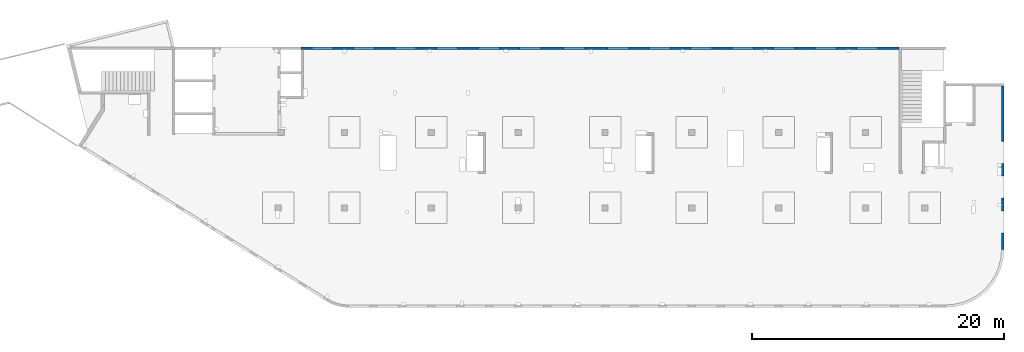
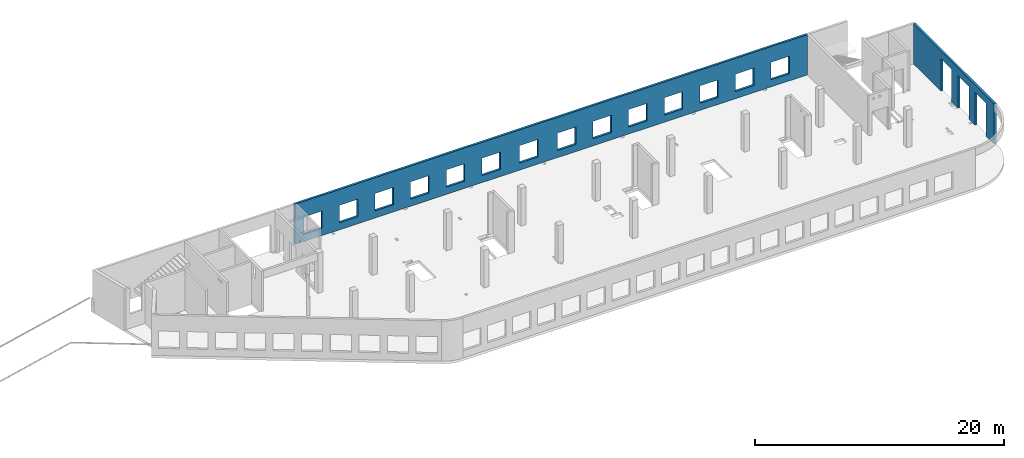
# One storey, part 7 of 7: 2 walls, 17 openings.
"""IFC4 building model written with IfcOpenShell, lengths in millimetres."""

from ifc_helpers import new_model, entity, si_unit, converted_unit, derived_unit, direction, frame, origin, place, context, subcontext, project, spatial, indexed_curve, outline, extrude, polygons, material, type_object, element, save


model = new_model("IFC4")

# Units and contexts
model_context = context("Model", 3, precision=0.01, world=origin(), true_north=direction((6.12303176911189e-17, 1.0)))
plan_context = context("Plan", 3, precision=0.01, world=origin(), true_north=direction((6.12303176911189e-17, 1.0)))
body_context = subcontext(model_context, "Body", "Model", "MODEL_VIEW")
ifc_project = project(units=[si_unit("LENGTHUNIT", "METRE", prefix="MILLI"), si_unit("AREAUNIT", "SQUARE_METRE"), si_unit("VOLUMEUNIT", "CUBIC_METRE"), converted_unit("PLANEANGLEUNIT", "DEGREE", entity("IfcRatioMeasure", 0.0174532925199433), si_unit("PLANEANGLEUNIT", "RADIAN"), dimensions=[0, 0, 0, 0, 0, 0, 0]), si_unit("MASSUNIT", "GRAM", prefix="KILO"), derived_unit("MASSDENSITYUNIT", [(si_unit("MASSUNIT", "GRAM", prefix="KILO"), 1), (si_unit("LENGTHUNIT", "METRE"), -3)]), derived_unit("MOMENTOFINERTIAUNIT", [(si_unit("LENGTHUNIT", "METRE"), 4)]), si_unit("TIMEUNIT", "SECOND"), si_unit("FREQUENCYUNIT", "HERTZ"), si_unit("THERMODYNAMICTEMPERATUREUNIT", "DEGREE_CELSIUS"), derived_unit("THERMALTRANSMITTANCEUNIT", [(si_unit("MASSUNIT", "GRAM", prefix="KILO"), 1), (si_unit("THERMODYNAMICTEMPERATUREUNIT", "KELVIN"), -1), (si_unit("TIMEUNIT", "SECOND"), -3)]), derived_unit("VOLUMETRICFLOWRATEUNIT", [(si_unit("LENGTHUNIT", "METRE"), 3), (si_unit("TIMEUNIT", "SECOND"), -1)]), derived_unit("MASSFLOWRATEUNIT", [(si_unit("MASSUNIT", "GRAM", prefix="KILO"), 1), (si_unit("TIMEUNIT", "SECOND"), -1)]), derived_unit("ROTATIONALFREQUENCYUNIT", [(si_unit("TIMEUNIT", "SECOND"), -1)]), si_unit("ELECTRICCURRENTUNIT", "AMPERE"), si_unit("ELECTRICVOLTAGEUNIT", "VOLT"), si_unit("POWERUNIT", "WATT"), si_unit("FORCEUNIT", "NEWTON", prefix="KILO"), si_unit("ILLUMINANCEUNIT", "LUX"), si_unit("LUMINOUSFLUXUNIT", "LUMEN"), si_unit("LUMINOUSINTENSITYUNIT", "CANDELA"), derived_unit("USERDEFINED", [(si_unit("MASSUNIT", "GRAM", prefix="KILO"), -1), (si_unit("LENGTHUNIT", "METRE"), -2), (si_unit("TIMEUNIT", "SECOND"), 3), (si_unit("LUMINOUSFLUXUNIT", "LUMEN"), 1)]), derived_unit("LINEARVELOCITYUNIT", [(si_unit("LENGTHUNIT", "METRE"), 1), (si_unit("TIMEUNIT", "SECOND"), -1)]), si_unit("PRESSUREUNIT", "PASCAL"), derived_unit("USERDEFINED", [(si_unit("LENGTHUNIT", "METRE"), -2), (si_unit("MASSUNIT", "GRAM", prefix="KILO"), 1), (si_unit("TIMEUNIT", "SECOND"), -2)]), derived_unit("LINEARFORCEUNIT", [(si_unit("MASSUNIT", "GRAM", prefix="KILO"), 1), (si_unit("LENGTHUNIT", "METRE"), 1), (si_unit("TIMEUNIT", "SECOND"), -2), (si_unit("LENGTHUNIT", "METRE"), -1)]), derived_unit("PLANARFORCEUNIT", [(si_unit("MASSUNIT", "GRAM", prefix="KILO"), 1), (si_unit("LENGTHUNIT", "METRE"), 1), (si_unit("TIMEUNIT", "SECOND"), -2), (si_unit("LENGTHUNIT", "METRE"), -2)])], contexts=[model_context, plan_context])

# Site, building, storey
site_placement = place(None, origin())
site = spatial("IfcSite", under=ifc_project, at=site_placement, CompositionType="ELEMENT")
building_placement = place(site_placement, origin())
building = spatial("IfcBuilding", under=site, at=building_placement, CompositionType="ELEMENT")
storey_placement = place(building_placement, frame((0.0, 0.0, 24000.0)))
storey = spatial("IfcBuildingStorey", under=building, at=storey_placement, Name="07", CompositionType="ELEMENT", Elevation=24000.0)

# Wall, openings
ifc_material = material()
wall_type = type_object("IfcWallType", Name=":ADSK_ 25_200", PredefinedType="STANDARD")
wall_1_placement = place(storey_placement, frame((73470.0, 17370.0, -150.0), z_axis=(0.0, 0.0, 1.0), x_axis=(0.0, -1.0, 0.0)))
wall_1 = element("IfcWall", 1, at=wall_1_placement, inside=storey, type_object=wall_type, material=ifc_material, Name=":ADSK_ 25_200", ObjectType=":ADSK_ 25_200", PredefinedType="NOTDEFINED", context=body_context, shape_type="Tessellation", body=[
    polygons([(12970.0, -99.9999999999918, 0.0), (12970.0, -99.9999999999918, 3200.0), (12970.0, -99.9999999999918, 3950.0), (0.0, -99.9999999999831, 3950.0), (0.0, -99.9999999999831, 0.0), (4394.9999999995, -99.9999999999946, 0.0), (4394.9999999995, -100.000000000003, 3200.0), (6144.9999999995, -100.000000000001, 3200.0), (6144.9999999995, -99.9999999999923, 0.0), (6320.00000000001, -99.999999999992, 0.0), (6485.00000000002, -99.9999999999918, 0.0), (7085.00000000002, -99.999999999991, 0.0), (7144.9999999995, -99.9999999999909, 0.0), (7144.9999999995, -99.9999999999996, 3200.0), (8894.9999999995, -99.9999999999972, 3200.0), (8894.9999999995, -99.9999999999886, 0.0), (9360.00000000001, -99.999999999988, 0.0), (9560.00000000001, -99.9999999999877, 0.0), (9895.00000000005, -99.9999999999959, 0.0), (9895.00000000005, -99.9999999999959, 3200.0), (11645.0, -99.9999999999936, 3200.0), (11645.0, -99.9999999999936, 0.0), (12970.0, 100.000000000006, 3950.0), (12970.0, 100.000000000006, 3200.0), (12970.0, 100.000000000006, 0.0), (11645.0, 100.000000000004, 0.0), (11645.0, 100.000000000316, 3200.0), (9895.00000000005, 100.000000000314, 3200.0), (9895.00000000004, 100.000000000002, 0.0), (8894.9999999995, 100.000000000001, 0.0), (8894.9999999995, 100.00000000033, 3200.0), (7144.9999999995, 100.000000000327, 3200.0), (7144.9999999995, 99.9999999999983, 0.0), (6144.9999999995, 99.9999999999969, 0.0), (6144.9999999995, 100.000000000326, 3200.0), (4394.9999999995, 100.000000000324, 3200.0), (4394.9999999995, 99.9999999999946, 0.0), (0.0, 100.000000000006, 0.0), (0.0, 100.000000000006, 3950.0)], [[[1, 2, 3, 4, 5, 6, 7, 8, 9, 10, 11, 12, 13, 14, 15, 16, 17, 18, 19, 20, 21, 22]], [[23, 24, 25, 26, 27, 28, 29, 30, 31, 32, 33, 34, 35, 36, 37, 38, 39]], [[5, 38, 37, 6]], [[3, 2, 1, 25, 24, 23]], [[4, 3, 23, 39]], [[5, 4, 39, 38]], [[20, 28, 27, 21]], [[28, 20, 19, 29]], [[21, 27, 26, 22]], [[14, 32, 31, 15]], [[32, 14, 13, 33]], [[15, 31, 30, 16]], [[7, 36, 35, 8]], [[36, 7, 6, 37]], [[8, 35, 34, 9]], [[33, 13, 12, 11, 10, 9, 34]], [[29, 19, 18, 17, 16, 30]], [[25, 1, 22, 26]]], closed=True),
])
placement_1 = place(wall_1_placement, frame((17370.0, -73470.0, 150.0), z_axis=(0.0, 0.0, 1.0), x_axis=(0.0, 1.0, 0.0)))
element("IfcOpeningElement", 2, at=placement_1, cuts=wall_1, Name=":ADSK_ 25_200", PredefinedType="OPENING", context=body_context, shape_type="SweptSolid", body=[
    extrude(outline(indexed_curve([(-1599.99999999999, -874.999999999999), (1600.0, -874.999999999999), (1600.0, 875.0), (-1599.99999999999, 875.0), (-1599.99999999999, -874.999999999999)], self_intersect=False)), frame((73370.0, 6600.0, 1450.0), z_axis=(1.0, 0.0, 0.0), x_axis=(0.0, 0.0, -1.0)), (0.0, 0.0, 1.0), 200.000000000968),
])
element("IfcOpeningElement", 3, at=placement_1, cuts=wall_1, Name=":ADSK_ 25_200", PredefinedType="OPENING", context=body_context, shape_type="SweptSolid", body=[
    extrude(outline(indexed_curve([(-1599.99999999999, -874.999999999999), (1600.0, -874.999999999999), (1600.0, 875.0), (-1599.99999999999, 875.0), (-1599.99999999999, -874.999999999999)], self_intersect=False)), frame((73370.0, 9350.0, 1450.0), z_axis=(1.0, 0.0, 0.0), x_axis=(0.0, 0.0, -1.0)), (0.0, 0.0, 1.0), 200.000000000968),
])
element("IfcOpeningElement", 4, at=placement_1, cuts=wall_1, Name=":ADSK_ 25_200", PredefinedType="OPENING", context=body_context, shape_type="SweptSolid", body=[
    extrude(outline(indexed_curve([(-1599.99999999999, -875.0), (1600.0, -875.0), (1600.0, 875.0), (-1599.99999999999, 875.0), (-1599.99999999999, -875.0)], self_intersect=False)), frame((73370.0, 12100.0, 1450.0), z_axis=(1.0, 0.0, 0.0), x_axis=(0.0, 0.0, -1.0)), (0.0, 0.0, 1.0), 200.000000000968),
])

wall_2_placement = place(storey_placement, frame((65230.0, 20400.0, -150.0), z_axis=(0.0, 0.0, 1.0), x_axis=(-1.0, 0.0, 0.0)))
wall_2 = element("IfcWall", 5, at=wall_2_placement, inside=storey, type_object=wall_type, material=ifc_material, Name=":ADSK_ 25_200", ObjectType=":ADSK_ 25_200", PredefinedType="NOTDEFINED", context=body_context, shape_type="Tessellation", body=[
    polygons([(8.66293703438714e-12, -99.9999999999989, 0.0), (47505.0, -99.9999999999989, 0.0), (47505.0, -99.9999999999989, 3950.0), (8.66293703438714e-12, -99.9999999999989, 3950.0), (28460.0, -100.000000000319, 2400.0), (30160.0, -100.000000000319, 2400.0), (30160.0, -100.000000000319, 700.00000000001), (28460.0, -100.000000000319, 700.00000000001), (1660.00000000009, -100.000000000319, 2400.0), (3360.00000000009, -100.000000000319, 2400.0), (3360.00000000009, -100.000000000319, 700.00000000001), (1660.00000000009, -100.000000000319, 700.00000000001), (4960.00000000009, -100.000000000319, 2400.0), (6660.00000000009, -100.000000000319, 2400.0), (6660.00000000009, -100.000000000319, 700.00000000001), (4960.00000000009, -100.000000000319, 700.00000000001), (8260.00000000008, -100.000000000319, 2400.0), (9960.00000000008, -100.000000000319, 2400.0), (9960.00000000008, -100.000000000319, 700.00000000001), (8260.00000000008, -100.000000000319, 700.00000000001), (11560.0000000001, -100.000000000319, 2400.0), (13260.0000000001, -100.000000000319, 2400.0), (13260.0000000001, -100.000000000319, 700.00000000001), (11560.0000000001, -100.000000000319, 700.00000000001), (14860.0000000001, -100.000000000319, 2400.0), (16560.0000000001, -100.000000000319, 2400.0), (16560.0000000001, -100.000000000319, 700.00000000001), (14860.0000000001, -100.000000000319, 700.00000000001), (18160.0000000001, -100.000000000319, 2400.0), (19860.0000000001, -100.000000000319, 2400.0), (19860.0000000001, -100.000000000319, 700.00000000001), (18160.0000000001, -100.000000000319, 700.00000000001), (21460.0000000001, -100.000000000319, 2400.0), (23160.0000000001, -100.000000000319, 2400.0), (23160.0000000001, -100.000000000319, 700.00000000001), (21460.0000000001, -100.000000000319, 700.00000000001), (24960.0000000001, -100.000000000319, 2400.0), (26660.0000000001, -100.000000000319, 2400.0), (26660.0000000001, -100.000000000319, 700.00000000001), (24960.0000000001, -100.000000000319, 700.00000000001), (31760.0000000001, -100.000000000319, 2400.0), (33460.0000000001, -100.000000000319, 2400.0), (33460.0000000001, -100.000000000319, 700.00000000001), (31760.0000000001, -100.000000000319, 700.00000000001), (35060.0000000001, -100.000000000319, 2400.0), (36760.0000000001, -100.000000000319, 2400.0), (36760.0000000001, -100.000000000319, 700.00000000001), (35060.0000000001, -100.000000000319, 700.00000000001), (38360.0000000001, -100.000000000319, 2400.0), (40060.0000000001, -100.000000000319, 2400.0), (40060.0000000001, -100.000000000319, 700.00000000001), (38360.0000000001, -100.000000000319, 700.00000000001), (41660.0, -100.000000000319, 2400.0), (43360.0, -100.000000000319, 2400.0), (43360.0, -100.000000000319, 700.00000000001), (41660.0, -100.000000000319, 700.00000000001), (44960.0, -100.000000000319, 2400.0), (46660.0, -100.000000000319, 2400.0), (46660.0, -100.000000000319, 700.00000000001), (44960.0, -100.000000000319, 700.00000000001), (8.66293703438714e-12, 99.9999999999989, 0.0), (8.66293703438714e-12, 99.9999999999989, 3950.0), (3860.00000000002, 99.9999999999989, 3950.0), (4160.00000000004, 99.9999999999989, 3950.0), (25630.0, 99.9999999999989, 3950.0), (25930.0, 99.9999999999989, 3950.0), (47305.0, 99.9999999999989, 3950.0), (47505.0, 99.9999999999989, 3950.0), (47505.0, 99.9999999999989, 0.0), (47305.0, 99.9999999999989, 0.0), (30160.0, 99.9999999999989, 2400.0), (28460.0, 99.9999999999989, 2400.0), (28460.0, 99.9999999999989, 700.00000000001), (30160.0, 99.9999999999989, 700.00000000001), (3360.00000000009, 99.9999999999989, 2400.0), (1660.00000000009, 99.9999999999989, 2400.0), (1660.00000000009, 99.9999999999989, 700.00000000001), (3360.00000000009, 99.9999999999989, 700.00000000001), (6660.00000000009, 99.9999999999989, 2400.0), (4960.00000000009, 99.9999999999989, 2400.0), (4960.00000000009, 99.9999999999989, 700.00000000001), (6660.00000000009, 99.9999999999989, 700.00000000001), (9960.00000000008, 99.9999999999989, 2400.0), (8260.00000000008, 99.9999999999989, 2400.0), (8260.00000000008, 99.9999999999989, 700.00000000001), (9960.00000000008, 99.9999999999989, 700.00000000001), (13260.0000000001, 99.9999999999989, 2400.0), (11560.0000000001, 99.9999999999989, 2400.0), (11560.0000000001, 99.9999999999989, 700.00000000001), (13260.0000000001, 99.9999999999989, 700.00000000001), (16560.0000000001, 99.9999999999989, 2400.0), (14860.0000000001, 99.9999999999989, 2400.0), (14860.0000000001, 99.9999999999989, 700.00000000001), (16560.0000000001, 99.9999999999989, 700.00000000001), (19860.0000000001, 99.9999999999989, 2400.0), (18160.0000000001, 99.9999999999989, 2400.0), (18160.0000000001, 99.9999999999989, 700.00000000001), (19860.0000000001, 99.9999999999989, 700.00000000001), (23160.0000000001, 99.9999999999989, 2400.0), (21460.0000000001, 99.9999999999989, 2400.0), (21460.0000000001, 99.9999999999989, 700.00000000001), (23160.0000000001, 99.9999999999989, 700.00000000001), (26660.0000000001, 99.9999999999989, 2400.0), (24960.0000000001, 99.9999999999989, 2400.0), (24960.0000000001, 99.9999999999989, 700.00000000001), (26660.0000000001, 99.9999999999989, 700.00000000001), (33460.0000000001, 99.9999999999989, 2400.0), (31760.0000000001, 99.9999999999989, 2400.0), (31760.0000000001, 99.9999999999989, 700.00000000001), (33460.0000000001, 99.9999999999989, 700.00000000001), (36760.0000000001, 99.9999999999989, 2400.0), (35060.0000000001, 99.9999999999989, 2400.0), (35060.0000000001, 99.9999999999989, 700.00000000001), (36760.0000000001, 99.9999999999989, 700.00000000001), (40060.0000000001, 99.9999999999989, 2400.0), (38360.0000000001, 99.9999999999989, 2400.0), (38360.0000000001, 99.9999999999989, 700.00000000001), (40060.0000000001, 99.9999999999989, 700.00000000001), (43360.0, 99.9999999999989, 2400.0), (41660.0, 99.9999999999989, 2400.0), (41660.0, 99.9999999999989, 700.00000000001), (43360.0, 99.9999999999989, 700.00000000001), (46660.0, 99.9999999999989, 2400.0), (44960.0, 99.9999999999989, 2400.0), (44960.0, 99.9999999999989, 700.00000000001), (46660.0, 99.9999999999989, 700.00000000001)], [[[1, 2, 3, 4], [5, 6, 7, 8], [9, 10, 11, 12], [13, 14, 15, 16], [17, 18, 19, 20], [21, 22, 23, 24], [25, 26, 27, 28], [29, 30, 31, 32], [33, 34, 35, 36], [37, 38, 39, 40], [41, 42, 43, 44], [45, 46, 47, 48], [49, 50, 51, 52], [53, 54, 55, 56], [57, 58, 59, 60]], [[61, 62, 63, 64, 65, 66, 67, 68, 69, 70], [71, 72, 73, 74], [75, 76, 77, 78], [79, 80, 81, 82], [83, 84, 85, 86], [87, 88, 89, 90], [91, 92, 93, 94], [95, 96, 97, 98], [99, 100, 101, 102], [103, 104, 105, 106], [107, 108, 109, 110], [111, 112, 113, 114], [115, 116, 117, 118], [119, 120, 121, 122], [123, 124, 125, 126]], [[2, 1, 61, 70, 69]], [[4, 3, 68, 67, 66, 65, 64, 63, 62]], [[1, 4, 62, 61]], [[3, 2, 69, 68]], [[6, 5, 72, 71]], [[6, 71, 74, 7]], [[7, 74, 73, 8]], [[72, 5, 8, 73]], [[10, 9, 76, 75]], [[10, 75, 78, 11]], [[11, 78, 77, 12]], [[76, 9, 12, 77]], [[14, 13, 80, 79]], [[14, 79, 82, 15]], [[15, 82, 81, 16]], [[80, 13, 16, 81]], [[18, 17, 84, 83]], [[18, 83, 86, 19]], [[19, 86, 85, 20]], [[84, 17, 20, 85]], [[22, 21, 88, 87]], [[22, 87, 90, 23]], [[23, 90, 89, 24]], [[88, 21, 24, 89]], [[26, 25, 92, 91]], [[26, 91, 94, 27]], [[27, 94, 93, 28]], [[92, 25, 28, 93]], [[30, 29, 96, 95]], [[30, 95, 98, 31]], [[31, 98, 97, 32]], [[96, 29, 32, 97]], [[34, 33, 100, 99]], [[34, 99, 102, 35]], [[35, 102, 101, 36]], [[100, 33, 36, 101]], [[38, 37, 104, 103]], [[38, 103, 106, 39]], [[39, 106, 105, 40]], [[104, 37, 40, 105]], [[42, 41, 108, 107]], [[42, 107, 110, 43]], [[43, 110, 109, 44]], [[108, 41, 44, 109]], [[46, 45, 112, 111]], [[46, 111, 114, 47]], [[47, 114, 113, 48]], [[112, 45, 48, 113]], [[50, 49, 116, 115]], [[50, 115, 118, 51]], [[51, 118, 117, 52]], [[116, 49, 52, 117]], [[54, 53, 120, 119]], [[54, 119, 122, 55]], [[55, 122, 121, 56]], [[120, 53, 56, 121]], [[58, 57, 124, 123]], [[58, 123, 126, 59]], [[59, 126, 125, 60]], [[124, 57, 60, 125]]], closed=True),
])
placement_2 = place(wall_2_placement, frame((65230.0, 20400.0, 150.0), z_axis=(0.0, 0.0, 1.0), x_axis=(-1.0, 0.0, 0.0)))
element("IfcOpeningElement", 6, at=placement_2, cuts=wall_2, Name=":ADSK_ 25_200", PredefinedType="OPENING", context=body_context, shape_type="SweptSolid", body=[
    extrude(outline(indexed_curve([(-850.000000000002, -849.999999999993), (850.0, -849.999999999993), (850.0, 849.999999999993), (-850.000000000002, 849.999999999993), (-850.000000000002, -849.999999999993)], self_intersect=False)), frame((19420.0, 20500.0, 1400.0), z_axis=(0.0, -1.0, 0.0), x_axis=(-1.0, 0.0, 0.0)), (0.0, 0.0, 1.0), 200.000000000959),
])
element("IfcOpeningElement", 7, at=placement_2, cuts=wall_2, Name=":ADSK_ 25_200", PredefinedType="OPENING", context=body_context, shape_type="SweptSolid", body=[
    extrude(outline(indexed_curve([(-850.000000000002, -849.999999999993), (849.999999999997, -849.999999999993), (849.999999999997, 849.999999999993), (-850.000000000002, 849.999999999993), (-850.000000000002, -849.999999999993)], self_intersect=False)), frame((22720.0, 20500.0, 1400.0), z_axis=(0.0, -1.0, 0.0), x_axis=(-1.0, 0.0, 0.0)), (0.0, 0.0, 1.0), 200.000000000959),
])
element("IfcOpeningElement", 8, at=placement_2, cuts=wall_2, Name=":ADSK_ 25_200", PredefinedType="OPENING", context=body_context, shape_type="SweptSolid", body=[
    extrude(outline(indexed_curve([(-850.000000000002, -849.999999999993), (849.999999999997, -849.999999999993), (849.999999999997, 849.999999999993), (-850.000000000002, 849.999999999993), (-850.000000000002, -849.999999999993)], self_intersect=False)), frame((26020.0, 20500.0, 1400.0), z_axis=(0.0, -1.0, 0.0), x_axis=(-1.0, 0.0, 0.0)), (0.0, 0.0, 1.0), 200.000000000959),
])
element("IfcOpeningElement", 9, at=placement_2, cuts=wall_2, Name=":ADSK_ 25_200", PredefinedType="OPENING", context=body_context, shape_type="SweptSolid", body=[
    extrude(outline(indexed_curve([(-850.000000000002, -849.999999999993), (849.999999999997, -849.999999999993), (849.999999999997, 849.999999999993), (-850.000000000002, 849.999999999993), (-850.000000000002, -849.999999999993)], self_intersect=False)), frame((29320.0, 20500.0, 1400.0), z_axis=(0.0, -1.0, 0.0), x_axis=(-1.0, 0.0, 0.0)), (0.0, 0.0, 1.0), 200.000000000959),
])
element("IfcOpeningElement", 10, at=placement_2, cuts=wall_2, Name=":ADSK_ 25_200", PredefinedType="OPENING", context=body_context, shape_type="SweptSolid", body=[
    extrude(outline(indexed_curve([(-849.999999999997, -849.999999999993), (850.000000000002, -849.999999999993), (850.000000000002, 849.999999999993), (-849.999999999997, 849.999999999993), (-849.999999999997, -849.999999999993)], self_intersect=False)), frame((32620.0, 20500.0, 1400.0), z_axis=(0.0, -1.0, 0.0), x_axis=(-1.0, 0.0, 0.0)), (0.0, 0.0, 1.0), 200.000000000959),
])
element("IfcOpeningElement", 11, at=placement_2, cuts=wall_2, Name=":ADSK_ 25_200", PredefinedType="OPENING", context=body_context, shape_type="SweptSolid", body=[
    extrude(outline(indexed_curve([(-849.999999999997, -849.999999999993), (850.000000000006, -849.999999999993), (850.000000000006, 849.999999999993), (-849.999999999997, 849.999999999993), (-849.999999999997, -849.999999999993)], self_intersect=False)), frame((39420.0, 20500.0, 1400.0), z_axis=(0.0, -1.0, 0.0), x_axis=(-1.0, 0.0, 0.0)), (0.0, 0.0, 1.0), 200.000000000959),
])
element("IfcOpeningElement", 12, at=placement_2, cuts=wall_2, Name=":ADSK_ 25_200", PredefinedType="OPENING", context=body_context, shape_type="SweptSolid", body=[
    extrude(outline(indexed_curve([(-850.000000000006, -849.999999999993), (849.999999999997, -849.999999999993), (849.999999999997, 849.999999999993), (-850.000000000006, 849.999999999993), (-850.000000000006, -849.999999999993)], self_intersect=False)), frame((42920.0, 20500.0, 1400.0), z_axis=(0.0, -1.0, 0.0), x_axis=(-1.0, 0.0, 0.0)), (0.0, 0.0, 1.0), 200.000000000959),
])
element("IfcOpeningElement", 13, at=placement_2, cuts=wall_2, Name=":ADSK_ 25_200", PredefinedType="OPENING", context=body_context, shape_type="SweptSolid", body=[
    extrude(outline(indexed_curve([(-849.999999999997, -849.999999999993), (850.000000000006, -849.999999999993), (850.000000000006, 849.999999999993), (-849.999999999997, 849.999999999993), (-849.999999999997, -849.999999999993)], self_intersect=False)), frame((46220.0, 20500.0, 1400.0), z_axis=(0.0, -1.0, 0.0), x_axis=(-1.0, 0.0, 0.0)), (0.0, 0.0, 1.0), 200.000000000959),
])
element("IfcOpeningElement", 14, at=placement_2, cuts=wall_2, Name=":ADSK_ 25_200", PredefinedType="OPENING", context=body_context, shape_type="SweptSolid", body=[
    extrude(outline(indexed_curve([(-849.999999999997, -849.999999999993), (850.000000000006, -849.999999999993), (850.000000000006, 849.999999999993), (-849.999999999997, 849.999999999993), (-849.999999999997, -849.999999999993)], self_intersect=False)), frame((49520.0, 20500.0, 1400.0), z_axis=(0.0, -1.0, 0.0), x_axis=(-1.0, 0.0, 0.0)), (0.0, 0.0, 1.0), 200.000000000959),
])
element("IfcOpeningElement", 15, at=placement_2, cuts=wall_2, Name=":ADSK_ 25_200", PredefinedType="OPENING", context=body_context, shape_type="SweptSolid", body=[
    extrude(outline(indexed_curve([(-849.999999999997, -849.999999999993), (850.000000000006, -849.999999999993), (850.000000000006, 849.999999999993), (-849.999999999997, 849.999999999993), (-849.999999999997, -849.999999999993)], self_intersect=False)), frame((52820.0, 20500.0, 1400.0), z_axis=(0.0, -1.0, 0.0), x_axis=(-1.0, 0.0, 0.0)), (0.0, 0.0, 1.0), 200.000000000959),
])
element("IfcOpeningElement", 16, at=placement_2, cuts=wall_2, Name=":ADSK_ 25_200", PredefinedType="OPENING", context=body_context, shape_type="SweptSolid", body=[
    extrude(outline(indexed_curve([(-849.999999999997, -849.999999999993), (850.000000000006, -849.999999999993), (850.000000000006, 849.999999999993), (-849.999999999997, 849.999999999993), (-849.999999999997, -849.999999999993)], self_intersect=False)), frame((56120.0, 20500.0, 1400.0), z_axis=(0.0, -1.0, 0.0), x_axis=(-1.0, 0.0, 0.0)), (0.0, 0.0, 1.0), 200.000000000959),
])
element("IfcOpeningElement", 17, at=placement_2, cuts=wall_2, Name=":ADSK_ 25_200", PredefinedType="OPENING", context=body_context, shape_type="SweptSolid", body=[
    extrude(outline(indexed_curve([(-849.999999999997, -849.999999999993), (850.000000000006, -849.999999999993), (850.000000000006, 849.999999999993), (-849.999999999997, 849.999999999993), (-849.999999999997, -849.999999999993)], self_intersect=False)), frame((59420.0, 20500.0, 1400.0), z_axis=(0.0, -1.0, 0.0), x_axis=(-1.0, 0.0, 0.0)), (0.0, 0.0, 1.0), 200.000000000959),
])
element("IfcOpeningElement", 18, at=placement_2, cuts=wall_2, Name=":ADSK_ 25_200", PredefinedType="OPENING", context=body_context, shape_type="SweptSolid", body=[
    extrude(outline(indexed_curve([(-849.999999999997, -849.999999999993), (850.000000000006, -849.999999999993), (850.000000000006, 849.999999999993), (-849.999999999997, 849.999999999993), (-849.999999999997, -849.999999999993)], self_intersect=False)), frame((62720.0, 20500.0, 1400.0), z_axis=(0.0, -1.0, 0.0), x_axis=(-1.0, 0.0, 0.0)), (0.0, 0.0, 1.0), 200.000000000959),
])
element("IfcOpeningElement", 19, at=placement_2, cuts=wall_2, Name=":ADSK_ 25_200", PredefinedType="OPENING", context=body_context, shape_type="SweptSolid", body=[
    extrude(outline(indexed_curve([(-849.999999999997, -849.999999999993), (850.000000000002, -849.999999999993), (850.000000000002, 849.999999999993), (-849.999999999997, 849.999999999993), (-849.999999999997, -849.999999999993)], self_intersect=False)), frame((35920.0, 20500.0, 1400.0), z_axis=(0.0, -1.0, 0.0), x_axis=(-1.0, 0.0, 0.0)), (0.0, 0.0, 1.0), 200.000000000959),
])

save(model, "model.ifc")
